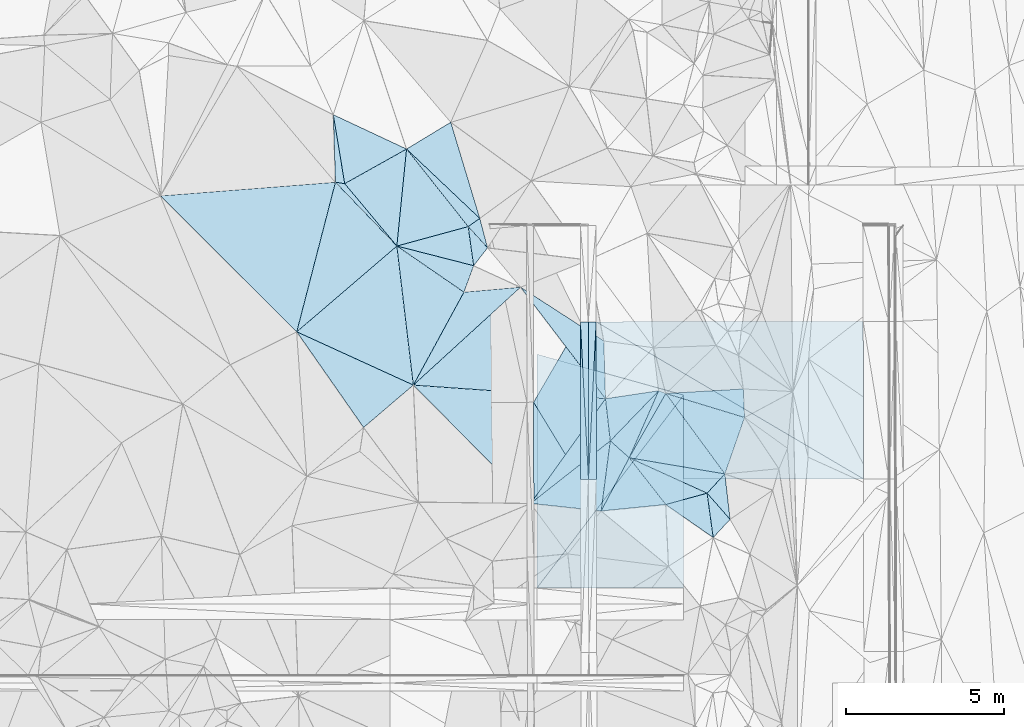
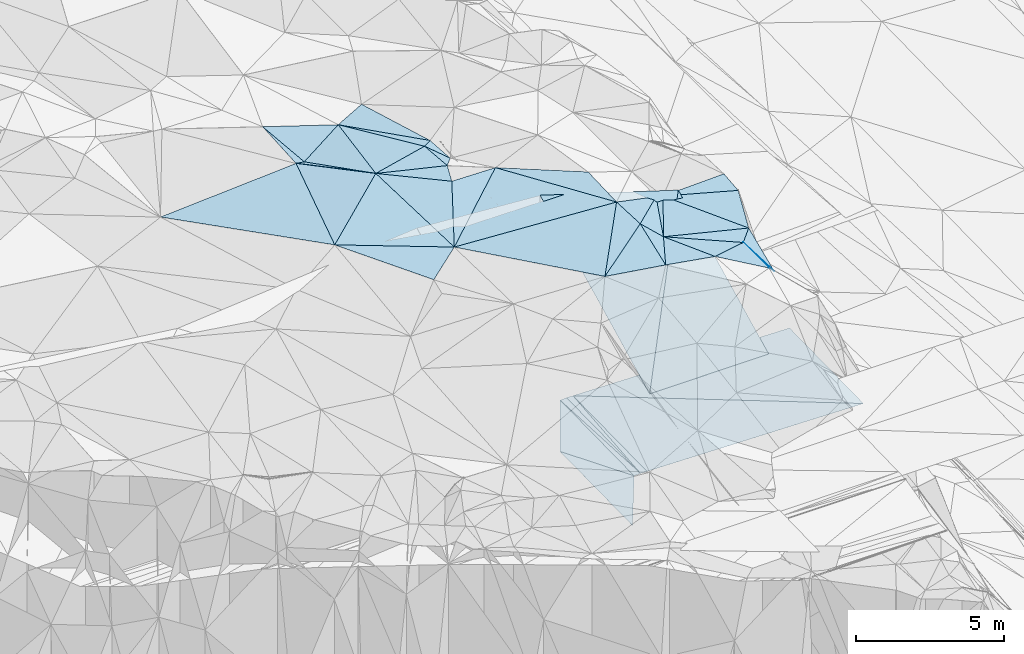
# One storey, part 79 of 275: 45 plates.
"""IFC2X3 building model written with IfcOpenShell, lengths in millimetres."""

from ifc_helpers import new_model, si_unit, frame, origin_with_axes, place, context, subcontext, project, spatial, polyline, outline, extrude, material, type_object, element, save


model = new_model("IFC2X3")

# Units and contexts
model_context = context("Model", 3, precision=1e-05, world=origin_with_axes())
body_context = subcontext(model_context, "Body", "Model", "MODEL_VIEW")
ifc_project = project(units=[si_unit("LENGTHUNIT", "METRE", prefix="MILLI"), si_unit("AREAUNIT", "SQUARE_METRE"), si_unit("VOLUMEUNIT", "CUBIC_METRE"), si_unit("MASSUNIT", "GRAM", prefix="KILO"), si_unit("TIMEUNIT", "SECOND"), si_unit("PLANEANGLEUNIT", "RADIAN"), si_unit("SOLIDANGLEUNIT", "STERADIAN"), si_unit("THERMODYNAMICTEMPERATUREUNIT", "DEGREE_CELSIUS"), si_unit("LUMINOUSINTENSITYUNIT", "LUMEN")], contexts=[model_context])

# Site, building, storey
site_placement = place(None, origin_with_axes())
site = spatial("IfcSite", under=ifc_project, at=site_placement, CompositionType="ELEMENT")
building_placement = place(site_placement, origin_with_axes())
building = spatial("IfcBuilding", under=site, at=building_placement, Name="Undefined", CompositionType="ELEMENT")
storey_placement = place(building_placement, origin_with_axes())
storey = spatial("IfcBuildingStorey", under=building, at=storey_placement, Name="Undefined", CompositionType="ELEMENT", Elevation=0.0)

# Plates
ifc_material = material()
plate_type_1 = type_object("IfcPlateType", PredefinedType="NOTDEFINED")
plate_1_placement = place(storey_placement, frame((-104094.644782462, 77711.1310853138, 42792.426719318), z_axis=(0.0499115279560036, 0.0195072604842656, -0.99856312077179), x_axis=(0.998751970162793, 0.000855051097686835, 0.0499376709865296)))
element("IfcPlate", 1, at=plate_1_placement, inside=storey, type_object=plate_type_1, material=ifc_material, Name="00_PR", context=body_context, shape_type="SweptSolid", body=[
    extrude(outline(polyline([(0.0, 0.0), (250.312026977539, 1.89174897968769e-10), (247.52180480957, 4982.27783203125), (0.0, 0.0)])), frame((-8.85201319254618e-08, 2.18876761149539e-07, -0.5000001331573), z_axis=(0.0, 0.0, 1.0), x_axis=(1.0, 0.0, 0.0)), (0.0, 0.0, 1.0), 1.0),
])
plate_2_placement = place(storey_placement, frame((-104094.644782462, 77711.1310853138, 42792.426719318), z_axis=(0.0498953511236693, 0.0195064415090151, -0.998563945211272), x_axis=(0.0513830470798486, -0.998535363603699, -0.0169384209895411)))
element("IfcPlate", 2, at=plate_2_placement, inside=storey, type_object=plate_type_1, material=ifc_material, Name="00_PR", context=body_context, shape_type="SweptSolid", body=[
    extrude(outline(polyline([(0.0, 0.0), (4988.42236328125, 3.48954927176237e-08), (4976.20849609375, 250.014541625977), (0.0, 0.0)])), frame((-8.85201319254618e-08, 2.18876761149539e-07, -0.5000001331573), z_axis=(0.0, 0.0, 1.0), x_axis=(1.0, 0.0, 0.0)), (0.0, 0.0, 1.0), 1.0),
])
plate_3_placement = place(storey_placement, frame((-103594.680469558, 77711.5591088604, 42799.9261959315), z_axis=(-0.0200088869669632, 0.0194389401804357, -0.999610810289187), x_axis=(-0.0488496159024904, -0.998635870197029, -0.0184421740041923)))
element("IfcPlate", 3, at=plate_3_placement, inside=storey, type_object=plate_type_1, material=ifc_material, Name="00_PR", context=body_context, shape_type="SweptSolid", body=[
    extrude(outline(polyline([(0.0, 0.0), (4988.34912109375, -2.07655830308795e-08), (12.333911895752, 249.745346069336), (0.0, 0.0)])), frame((-8.85201319254618e-08, 2.18876761149539e-07, -0.5000001331573), z_axis=(0.0, 0.0, 1.0), x_axis=(1.0, 0.0, 0.0)), (0.0, 0.0, 1.0), 1.0),
])
plate_4_placement = place(storey_placement, frame((-103838.359411258, 72730.0148818088, 42707.9301957771), z_axis=(-0.0200249727975942, 0.0194397208131985, -0.999610472993936), x_axis=(0.0488496158985749, 0.998635870197188, 0.0184421740059628)))
element("IfcPlate", 4, at=plate_4_placement, inside=storey, type_object=plate_type_1, material=ifc_material, Name="00_PR", context=body_context, shape_type="SweptSolid", body=[
    extrude(outline(polyline([(0.0, 0.0), (4988.34912109375, -2.07655830308795e-08), (12.5400276184082, 249.734832763672), (0.0, 0.0)])), frame((-8.85201319254618e-08, 2.18876761149539e-07, -0.5000001331573), z_axis=(0.0, 0.0, 1.0), x_axis=(1.0, 0.0, 0.0)), (0.0, 0.0, 1.0), 1.0),
])
plate_type_2 = type_object("IfcPlateType", PredefinedType="NOTDEFINED")
plate_5_placement = place(storey_placement, frame((-101618.017587406, 75531.2384662934, 51629.5000677969), z_axis=(0.00624082271276018, 0.0161315410796943, -0.999850401567285), x_axis=(0.932639023347854, -0.360810825958369, 1.38790676176126e-10)))
element("IfcPlate", 5, at=plate_5_placement, inside=storey, type_object=plate_type_2, material=ifc_material, Name="00", context=body_context, shape_type="SweptSolid", body=[
    extrude(outline(polyline([(0.0, 0.0), (240.416305541992, 8.0763129517436e-10), (-106.066017150879, 2312.58520507813), (0.0, 0.0)])), frame((-8.85201319254618e-08, 2.18876761149539e-07, -0.5000001331573), z_axis=(0.0, 0.0, 1.0), x_axis=(1.0, 0.0, 0.0)), (0.0, 0.0, 1.0), 1.0),
])
plate_type_3 = type_object("IfcPlateType", PredefinedType="NOTDEFINED")
plate_6_placement = place(storey_placement, frame((-105563.740608204, 70283.051901466, 42647.6330961536), z_axis=(4.16340783486055e-05, 0.0195077275703737, -0.999809705309787), x_axis=(-0.00168204510044178, 0.999808293172789, 0.0195076299738202)))
element("IfcPlate", 6, at=plate_6_placement, inside=storey, type_object=plate_type_3, material=ifc_material, Name="00_PR", context=body_context, shape_type="SweptSolid", body=[
    extrude(outline(polyline([(0.0, 0.0), (4885.9345703125, 8.57107806950808e-09), (2444.52392578125, 1479.50512695313), (0.0, 0.0)])), frame((-8.85201319254618e-08, 2.18876761149539e-07, -0.5000001331573), z_axis=(0.0, 0.0, 1.0), x_axis=(1.0, 0.0, 0.0)), (0.0, 0.0, 1.0), 1.0),
])
plate_type_4 = type_object("IfcPlateType", PredefinedType="NOTDEFINED")
plate_7_placement = place(storey_placement, frame((-105571.959004431, 75168.0496738251, 42742.9460960159), z_axis=(-2.47095844767252e-05, 0.0194673778358508, -0.999810492338239), x_axis=(0.502232605744066, 0.864568933754898, 0.0168216679745114)))
element("IfcPlate", 7, at=plate_7_placement, inside=storey, type_object=plate_type_4, material=ifc_material, Name="00_PR", context=body_context, shape_type="SweptSolid", body=[
    extrude(outline(polyline([(0.0, 0.0), (2941.4443359375, -1.75496097654104e-08), (-1363.89514160156, 2507.82983398438), (0.0, 0.0)])), frame((-8.85201319254618e-08, 2.18876761149539e-07, -0.5000001331573), z_axis=(0.0, 0.0, 1.0), x_axis=(1.0, 0.0, 0.0)), (0.0, 0.0, 1.0), 1.0),
])
plate_type_5 = type_object("IfcPlateType", PredefinedType="NOTDEFINED")
plate_8_placement = place(storey_placement, frame((-103594.680469558, 77711.5591088604, 42799.9261959315), z_axis=(-0.0200101558426408, 0.0194676111996677, -0.999610226927142), x_axis=(0.999799658022717, 0.000876953113859866, -0.0199968690272809)))
element("IfcPlate", 8, at=plate_8_placement, inside=storey, type_object=plate_type_5, material=ifc_material, Name="00_PR", context=body_context, shape_type="SweptSolid", body=[
    extrude(outline(polyline([(0.0, 0.0), (8442.771484375, -2.21189111471176e-09), (8446.765625, 4975.095703125), (0.0, 0.0)])), frame((-8.85201319254618e-08, 2.18876761149539e-07, -0.5000001331573), z_axis=(0.0, 0.0, 1.0), x_axis=(1.0, 0.0, 0.0)), (0.0, 0.0, 1.0), 1.0),
])
plate_type_6 = type_object("IfcPlateType", PredefinedType="NOTDEFINED")
plate_9_placement = place(storey_placement, frame((-95147.1826396286, 72744.8154070704, 42534.0961952218), z_axis=(-0.020026562689852, 0.0194397178099337, -0.999610441201121), x_axis=(-0.99979858505382, -0.00170321912043205, 0.0199972090304668)))
element("IfcPlate", 9, at=plate_9_placement, inside=storey, type_object=plate_type_6, material=ifc_material, Name="00_PR", context=body_context, shape_type="SweptSolid", body=[
    extrude(outline(polyline([(0.0, 0.0), (8442.8779296875, 9.31322574615479e-10), (8442.65234375, 4982.072265625), (0.0, 0.0)])), frame((-8.85201319254618e-08, 2.18876761149539e-07, -0.5000001331573), z_axis=(0.0, 0.0, 1.0), x_axis=(1.0, 0.0, 0.0)), (0.0, 0.0, 1.0), 1.0),
])
plate_type_7 = type_object("IfcPlateType", PredefinedType="NOTDEFINED")
plate_10_placement = place(storey_placement, frame((-109372.918102047, 75711.0015704377, 52159.503996703), z_axis=(-0.0424843865869005, 0.119112827589882, -0.991971376199877), x_axis=(-0.906017638237855, 0.413883575863438, 0.088500987748122)))
element("IfcPlate", 10, at=plate_10_placement, inside=storey, type_object=plate_type_7, material=ifc_material, Name="00", context=body_context, shape_type="SweptSolid", body=[
    extrude(outline(polyline([(0.0, 0.0), (4067.75122070313, 2.28319549933076e-08), (2339.84326171875, 3796.12084960938), (0.0, 0.0)])), frame((-8.85201319254618e-08, 2.18876761149539e-07, -0.5000001331573), z_axis=(0.0, 0.0, 1.0), x_axis=(1.0, 0.0, 0.0)), (0.0, 0.0, 1.0), 1.0),
])
plate_type_8 = type_object("IfcPlateType", PredefinedType="NOTDEFINED")
plate_11_placement = place(storey_placement, frame((-109894.236215448, 80105.3789736677, 52709.502000343), z_axis=(0.08945127564701, 0.00405021772779605, -0.995982964222521), x_axis=(-0.640329731326981, 0.766171760121747, -0.0543936500950232)))
element("IfcPlate", 11, at=plate_11_placement, inside=storey, type_object=plate_type_8, material=ifc_material, Name="00", context=body_context, shape_type="SweptSolid", body=[
    extrude(outline(polyline([(0.0, 0.0), (2573.82983398438, -3.59432306140661e-09), (2150.4140625, 2206.83471679688), (0.0, 0.0)])), frame((-8.85201319254618e-08, 2.18876761149539e-07, -0.5000001331573), z_axis=(0.0, 0.0, 1.0), x_axis=(1.0, 0.0, 0.0)), (0.0, 0.0, 1.0), 1.0),
])
plate_type_9 = type_object("IfcPlateType", PredefinedType="NOTDEFINED")
plate_12_placement = place(storey_placement, frame((-100829.739268023, 75394.5654516798, 51708.8947862122), z_axis=(0.00401439643131906, 0.447209958192911, -0.894420000846575), x_axis=(-5.11789581372139e-05, -0.894427148801689, -0.447213676967951)))
element("IfcPlate", 12, at=plate_12_placement, inside=storey, type_object=plate_type_9, material=ifc_material, Name="00_PR", context=body_context, shape_type="SweptSolid", body=[
    extrude(outline(polyline([(0.0, 0.0), (6821.87890625, -4.57512214779854e-08), (6831.1298828125, 4638.80615234375), (0.0, 0.0)])), frame((-8.85201319254618e-08, 2.18876761149539e-07, -0.5000001331573), z_axis=(0.0, 0.0, 1.0), x_axis=(1.0, 0.0, 0.0)), (0.0, 0.0, 1.0), 1.0),
])
plate_type_10 = type_object("IfcPlateType", PredefinedType="NOTDEFINED")
plate_13_placement = place(storey_placement, frame((-105468.85778225, 69293.1580861564, 48637.3697850271), z_axis=(0.00401439643131906, 0.447209958192911, -0.894420000846575), x_axis=(5.12609174268665e-05, 0.894427213806252, 0.447213546949446)))
element("IfcPlate", 13, at=plate_13_placement, inside=storey, type_object=plate_type_10, material=ifc_material, Name="00_PR", context=body_context, shape_type="SweptSolid", body=[
    extrude(outline(polyline([(0.0, 0.0), (8266.154296875, 5.1964889280498e-08), (6831.13037109375, 4638.8056640625), (0.0, 0.0)])), frame((-8.85201319254618e-08, 2.18876761149539e-07, -0.5000001331573), z_axis=(0.0, 0.0, 1.0), x_axis=(1.0, 0.0, 0.0)), (0.0, 0.0, 1.0), 1.0),
])
plate_type_11 = type_object("IfcPlateType", PredefinedType="NOTDEFINED")
plate_14_placement = place(storey_placement, frame((-107640.148772457, 80719.3908715709, 52669.5263252078), z_axis=(-0.261202900071324, 0.185393050024925, -0.947313286086913), x_axis=(0.810020855690639, 0.575867445029905, -0.11064763486372)))
element("IfcPlate", 14, at=plate_14_placement, inside=storey, type_object=plate_type_11, material=ifc_material, Name="00", context=body_context, shape_type="SweptSolid", body=[
    extrude(outline(polyline([(0.0, 0.0), (451.884948730469, 6.69388100504875e-10), (144.284515380859, 944.92431640625), (0.0, 0.0)])), frame((-8.85201319254618e-08, 2.18876761149539e-07, -0.5000001331573), z_axis=(0.0, 0.0, 1.0), x_axis=(1.0, 0.0, 0.0)), (0.0, 0.0, 1.0), 1.0),
])
plate_type_12 = type_object("IfcPlateType", PredefinedType="NOTDEFINED")
plate_15_placement = place(storey_placement, frame((-109894.249426074, 80105.375151897, 52709.5009800692), z_axis=(0.0630464638512558, -0.00363821455273105, -0.998003961310135), x_axis=(-0.758610626117883, -0.649949807377444, -0.0455539880916829)))
element("IfcPlate", 15, at=plate_15_placement, inside=storey, type_object=plate_type_12, material=ifc_material, Name="00", context=body_context, shape_type="SweptSolid", body=[
    extrude(outline(polyline([(0.0, 0.0), (4170.875, 3.28291207551956e-08), (167.614700317383, 2797.73217773438), (0.0, 0.0)])), frame((-8.85201319254618e-08, 2.18876761149539e-07, -0.5000001331573), z_axis=(0.0, 0.0, 1.0), x_axis=(1.0, 0.0, 0.0)), (0.0, 0.0, 1.0), 1.0),
])
plate_type_13 = type_object("IfcPlateType", PredefinedType="NOTDEFINED")
plate_16_placement = place(storey_placement, frame((-107465.796251951, 79484.3194922299, 52559.5012725631), z_axis=(-0.0479332469146287, 0.0534653455888724, -0.997418598513826), x_axis=(-0.345767543557187, -0.937716688509573, -0.0336484459235405)))
element("IfcPlate", 16, at=plate_16_placement, inside=storey, type_object=plate_type_13, material=ifc_material, Name="00", context=body_context, shape_type="SweptSolid", body=[
    extrude(outline(polyline([(0.0, 0.0), (891.571655273438, 4.30736690759659e-09), (252.251174926758, 2498.45336914063), (0.0, 0.0)])), frame((-8.85201319254618e-08, 2.18876761149539e-07, -0.5000001331573), z_axis=(0.0, 0.0, 1.0), x_axis=(1.0, 0.0, 0.0)), (0.0, 0.0, 1.0), 1.0),
])
plate_type_14 = type_object("IfcPlateType", PredefinedType="NOTDEFINED")
plate_17_placement = place(storey_placement, frame((-102551.274391549, 73413.0873306711, 51589.507800875), z_axis=(-0.102743226010443, 0.143219198698545, -0.984343482039229), x_axis=(0.978177130287567, -0.16511346138306, -0.12612314082866)))
element("IfcPlate", 17, at=plate_17_placement, inside=storey, type_object=plate_type_14, material=ifc_material, Name="00", context=body_context, shape_type="SweptSolid", body=[
    extrude(outline(polyline([(0.0, 0.0), (3092.21606445313, -1.52213033288717e-08), (2647.1630859375, 699.519714355469), (0.0, 0.0)])), frame((-8.85201319254618e-08, 2.18876761149539e-07, -0.5000001331573), z_axis=(0.0, 0.0, 1.0), x_axis=(1.0, 0.0, 0.0)), (0.0, 0.0, 1.0), 1.0),
])
plate_type_15 = type_object("IfcPlateType", PredefinedType="NOTDEFINED")
plate_18_placement = place(storey_placement, frame((-103436.891331539, 71731.3669856792, 51759.5044286829), z_axis=(-0.0583370506278532, 0.119417171706982, -0.99112881484979), x_axis=(-0.991720817456399, 0.106836700823929, 0.0712442248934615)))
element("IfcPlate", 18, at=plate_18_placement, inside=storey, type_object=plate_type_15, material=ifc_material, Name="00", context=body_context, shape_type="SweptSolid", body=[
    extrude(outline(polyline([(0.0, 0.0), (2245.79614257813, 1.48429535329342e-09), (-31.7036800384521, 2248.3759765625), (0.0, 0.0)])), frame((-8.85201319254618e-08, 2.18876761149539e-07, -0.5000001331573), z_axis=(0.0, 0.0, 1.0), x_axis=(1.0, 0.0, 0.0)), (0.0, 0.0, 1.0), 1.0),
])
plate_type_16 = type_object("IfcPlateType", PredefinedType="NOTDEFINED")
plate_19_placement = place(storey_placement, frame((-109894.280336887, 80105.4391137231, 52709.5038719452), z_axis=(0.00120830272819888, 0.124330446541354, -0.992240132260001), x_axis=(0.822128946847772, -0.565006678668483, -0.0697957578580838)))
element("IfcPlate", 19, at=plate_19_placement, inside=storey, type_object=plate_type_16, material=ifc_material, Name="00", context=body_context, shape_type="SweptSolid", body=[
    extrude(outline(polyline([(0.0, 0.0), (2578.95336914063, -7.80710252001882e-09), (2949.91772460938, 3344.15698242188), (0.0, 0.0)])), frame((-8.85201319254618e-08, 2.18876761149539e-07, -0.5000001331573), z_axis=(0.0, 0.0, 1.0), x_axis=(1.0, 0.0, 0.0)), (0.0, 0.0, 1.0), 1.0),
])
plate_type_17 = type_object("IfcPlateType", PredefinedType="NOTDEFINED")
plate_20_placement = place(storey_placement, frame((-103352.179348122, 77104.404641422, 52299.5018860323), z_axis=(0.0269184658026584, 0.0826657823630834, -0.996213714332989), x_axis=(0.0285336282030727, -0.996232314273623, -0.0818963250615655)))
element("IfcPlate", 20, at=plate_20_placement, inside=storey, type_object=plate_type_17, material=ifc_material, Name="00", context=body_context, shape_type="SweptSolid", body=[
    extrude(outline(polyline([(0.0, 0.0), (1831.583984375, 2.18278728425503e-10), (-1775.23937988281, 2583.83935546875), (0.0, 0.0)])), frame((-8.85201319254618e-08, 2.18876761149539e-07, -0.5000001331573), z_axis=(0.0, 0.0, 1.0), x_axis=(1.0, 0.0, 0.0)), (0.0, 0.0, 1.0), 1.0),
])
plate_type_18 = type_object("IfcPlateType", PredefinedType="NOTDEFINED")
plate_21_placement = place(storey_placement, frame((-109372.948451286, 75711.0317195909, 52159.510811722), z_axis=(-0.103215070282376, 0.179420044480136, -0.978343036416854), x_axis=(0.475187264867613, 0.87298596323488, 0.109966228008901)))
element("IfcPlate", 21, at=plate_21_placement, inside=storey, type_object=plate_type_18, material=ifc_material, Name="00", context=body_context, shape_type="SweptSolid", body=[
    extrude(outline(polyline([(0.0, 0.0), (3364.66943359375, 5.99538907408714e-09), (4334.333984375, 1520.4443359375), (0.0, 0.0)])), frame((-8.85201319254618e-08, 2.18876761149539e-07, -0.5000001331573), z_axis=(0.0, 0.0, 1.0), x_axis=(1.0, 0.0, 0.0)), (0.0, 0.0, 1.0), 1.0),
])
plate_type_19 = type_object("IfcPlateType", PredefinedType="NOTDEFINED")
plate_22_placement = place(storey_placement, frame((-117363.11470885, 81690.7903295136, 52569.5000288199), z_axis=(0.000834528412102019, 0.0124732808125638, -0.999921857360914), x_axis=(0.996960342197155, 0.0778898122067393, 0.0018036741752551)))
element("IfcPlate", 22, at=plate_22_placement, inside=storey, type_object=plate_type_19, material=ifc_material, Name="00", context=body_context, shape_type="SweptSolid", body=[
    extrude(outline(polyline([(0.0, 0.0), (5544.240234375, -6.53380993753672e-09), (3956.95336914063, 4618.86572265625), (0.0, 0.0)])), frame((-8.85201319254618e-08, 2.18876761149539e-07, -0.5000001331573), z_axis=(0.0, 0.0, 1.0), x_axis=(1.0, 0.0, 0.0)), (0.0, 0.0, 1.0), 1.0),
])
plate_type_20 = type_object("IfcPlateType", PredefinedType="NOTDEFINED")
plate_23_placement = place(storey_placement, frame((-103299.952395257, 75279.7299230715, 52149.5029351971), z_axis=(-0.0426612703769056, 0.099594682755939, -0.994113129968905), x_axis=(0.112521919235564, -0.988209360144718, -0.103831971058594)))
element("IfcPlate", 23, at=plate_23_placement, inside=storey, type_object=plate_type_20, material=ifc_material, Name="00", context=body_context, shape_type="SweptSolid", body=[
    extrude(outline(polyline([(0.0, 0.0), (1348.33227539063, 1.71712599694729e-09), (3027.29516601563, 2724.5703125), (0.0, 0.0)])), frame((-8.85201319254618e-08, 2.18876761149539e-07, -0.5000001331573), z_axis=(0.0, 0.0, 1.0), x_axis=(1.0, 0.0, 0.0)), (0.0, 0.0, 1.0), 1.0),
])
plate_type_21 = type_object("IfcPlateType", PredefinedType="NOTDEFINED")
plate_24_placement = place(storey_placement, frame((-105664.063318216, 71971.2742854486, 51919.5011216795), z_axis=(0.0031241781235292, 0.0671295595838872, -0.997739375659358), x_axis=(-0.703440316903041, 0.709295184604608, 0.0455199039109672)))
element("IfcPlate", 24, at=plate_24_placement, inside=storey, type_object=plate_type_21, material=ifc_material, Name="00", context=body_context, shape_type="SweptSolid", body=[
    extrude(outline(polyline([(0.0, 0.0), (5272.4189453125, 1.16779119707644e-09), (694.102661132813, 4013.23071289063), (0.0, 0.0)])), frame((-8.85201319254618e-08, 2.18876761149539e-07, -0.5000001331573), z_axis=(0.0, 0.0, 1.0), x_axis=(1.0, 0.0, 0.0)), (0.0, 0.0, 1.0), 1.0),
])
plate_type_22 = type_object("IfcPlateType", PredefinedType="NOTDEFINED")
plate_25_placement = place(storey_placement, frame((-100088.547425498, 72293.3336495574, 51169.6889610928), z_axis=(-0.78287703997348, 0.0119130016132518, -0.622062392911615), x_axis=(0.504103260418382, -0.573865491089101, -0.645413279203815)))
element("IfcPlate", 25, at=plate_25_placement, inside=storey, type_object=plate_type_22, material=ifc_material, Name="00", context=body_context, shape_type="SweptSolid", body=[
    extrude(outline(polyline([(0.0, 0.0), (1440.93725585938, -8.9130480773747e-10), (1075.96643066406, 957.547058105469), (0.0, 0.0)])), frame((-8.85201319254618e-08, 2.18876761149539e-07, -0.5000001331573), z_axis=(0.0, 0.0, 1.0), x_axis=(1.0, 0.0, 0.0)), (0.0, 0.0, 1.0), 1.0),
])
plate_type_23 = type_object("IfcPlateType", PredefinedType="NOTDEFINED")
plate_26_placement = place(storey_placement, frame((-99526.7158601399, 72902.6781538372, 51199.6183855585), z_axis=(-0.455854762584172, 0.457930781985056, -0.76321414710413), x_axis=(0.0949248522882564, -0.827587694194315, -0.553252095193674)))
element("IfcPlate", 26, at=plate_26_placement, inside=storey, type_object=plate_type_23, material=ifc_material, Name="00", context=body_context, shape_type="SweptSolid", body=[
    extrude(outline(polyline([(0.0, 0.0), (1735.19445800781, -1.16997398436069e-08), (467.382751464844, 684.801696777344), (0.0, 0.0)])), frame((-8.85201319254618e-08, 2.18876761149539e-07, -0.5000001331573), z_axis=(0.0, 0.0, 1.0), x_axis=(1.0, 0.0, 0.0)), (0.0, 0.0, 1.0), 1.0),
])
plate_type_24 = type_object("IfcPlateType", PredefinedType="NOTDEFINED")
plate_27_placement = place(storey_placement, frame((-102551.279660649, 73413.0577472824, 51589.5050038124), z_axis=(-0.113444058079821, 0.0841272177214205, -0.989976291092284), x_axis=(0.494964677961901, 0.868744704364515, 0.0171057361338932)))
element("IfcPlate", 27, at=plate_27_placement, inside=storey, type_object=plate_type_24, material=ifc_material, Name="00", context=body_context, shape_type="SweptSolid", body=[
    extrude(outline(polyline([(0.0, 0.0), (2338.39697265625, -6.66477717459202e-09), (1046.91381835938, 2909.59985351563), (0.0, 0.0)])), frame((-8.85201319254618e-08, 2.18876761149539e-07, -0.5000001331573), z_axis=(0.0, 0.0, 1.0), x_axis=(1.0, 0.0, 0.0)), (0.0, 0.0, 1.0), 1.0),
])
plate_type_25 = type_object("IfcPlateType", PredefinedType="NOTDEFINED")
plate_28_placement = place(storey_placement, frame((-103148.448561385, 73947.3250710095, 52009.5655816061), z_axis=(-0.468870579086385, 0.159094565412475, -0.868820637026661), x_axis=(0.659991257359202, -0.590606747976077, -0.464322312036092)))
element("IfcPlate", 28, at=plate_28_placement, inside=storey, type_object=plate_type_25, material=ifc_material, Name="00", context=body_context, shape_type="SweptSolid", body=[
    extrude(outline(polyline([(0.0, 0.0), (904.544067382813, 4.54019755125046e-09), (1234.32348632813, 1879.53332519531), (0.0, 0.0)])), frame((-8.85201319254618e-08, 2.18876761149539e-07, -0.5000001331573), z_axis=(0.0, 0.0, 1.0), x_axis=(1.0, 0.0, 0.0)), (0.0, 0.0, 1.0), 1.0),
])
plate_type_26 = type_object("IfcPlateType", PredefinedType="NOTDEFINED")
plate_29_placement = place(storey_placement, frame((-99895.0064686403, 70891.8537124908, 50899.5111910996), z_axis=(-0.121947828891443, 0.171517209932465, -0.97760450782801), x_axis=(-0.804708028521867, 0.559487818088166, 0.198540600994842)))
element("IfcPlate", 29, at=plate_29_placement, inside=storey, type_object=plate_type_26, material=ifc_material, Name="00", context=body_context, shape_type="SweptSolid", body=[
    extrude(outline(polyline([(0.0, 0.0), (1863.5986328125, -2.02635419555008e-09), (993.239624023438, 1043.1083984375), (0.0, 0.0)])), frame((-8.85201319254618e-08, 2.18876761149539e-07, -0.5000001331573), z_axis=(0.0, 0.0, 1.0), x_axis=(1.0, 0.0, 0.0)), (0.0, 0.0, 1.0), 1.0),
])
plate_type_27 = type_object("IfcPlateType", PredefinedType="NOTDEFINED")
plate_30_placement = place(storey_placement, frame((-113058.38506023, 77394.5497141232, 52519.5021873876), z_axis=(-0.0677365984436262, 0.0646119283224315, -0.99560888502953), x_axis=(0.906017638307265, -0.413883575893536, -0.0885009868967903)))
element("IfcPlate", 30, at=plate_30_placement, inside=storey, type_object=plate_type_27, material=ifc_material, Name="00", context=body_context, shape_type="SweptSolid", body=[
    extrude(outline(polyline([(0.0, 0.0), (4067.75122070313, 2.28319549933076e-08), (3196.09033203125, 1873.26110839844), (0.0, 0.0)])), frame((-8.85201319254618e-08, 2.18876761149539e-07, -0.5000001331573), z_axis=(0.0, 0.0, 1.0), x_axis=(1.0, 0.0, 0.0)), (0.0, 0.0, 1.0), 1.0),
])
plate_type_28 = type_object("IfcPlateType", PredefinedType="NOTDEFINED")
plate_31_placement = place(storey_placement, frame((-100088.211159355, 72293.3912042277, 51169.507121813), z_axis=(-0.110346449702483, 0.127018862347515, -0.985743308192351), x_axis=(-0.961659767781708, -0.264182132172222, 0.0736090488389199)))
element("IfcPlate", 31, at=plate_31_placement, inside=storey, type_object=plate_type_28, material=ifc_material, Name="00", context=body_context, shape_type="SweptSolid", body=[
    extrude(outline(polyline([(0.0, 0.0), (1358.52856445313, -3.40514816343784e-09), (2103.74658203125, 1752.44116210938), (0.0, 0.0)])), frame((-8.85201319254618e-08, 2.18876761149539e-07, -0.5000001331573), z_axis=(0.0, 0.0, 1.0), x_axis=(1.0, 0.0, 0.0)), (0.0, 0.0, 1.0), 1.0),
])
plate_type_29 = type_object("IfcPlateType", PredefinedType="NOTDEFINED")
plate_32_placement = place(storey_placement, frame((-101394.71613031, 71934.4416589704, 51269.5142491488), z_axis=(-0.235665467839818, 0.0259030979606526, -0.971488968946061), x_axis=(-0.967886695360361, -0.096264999264893, 0.232224879935225)))
element("IfcPlate", 32, at=plate_32_placement, inside=storey, type_object=plate_type_29, material=ifc_material, Name="00", context=body_context, shape_type="SweptSolid", body=[
    extrude(outline(polyline([(0.0, 0.0), (2110.02368164063, 6.11180439591408e-10), (1051.45739746094, 1587.71447753906), (0.0, 0.0)])), frame((-8.85201319254618e-08, 2.18876761149539e-07, -0.5000001331573), z_axis=(0.0, 0.0, 1.0), x_axis=(1.0, 0.0, 0.0)), (0.0, 0.0, 1.0), 1.0),
])
plate_type_30 = type_object("IfcPlateType", PredefinedType="NOTDEFINED")
plate_33_placement = place(storey_placement, frame((-109894.301098861, 80105.418477037, 52709.5021138553), z_axis=(-0.040274237277663, 0.0830062891092666, -0.99573487524542), x_axis=(0.964717748391179, 0.262729207345162, -0.0171181058192192)))
element("IfcPlate", 33, at=plate_33_placement, inside=storey, type_object=plate_type_30, material=ifc_material, Name="00", context=body_context, shape_type="SweptSolid", body=[
    extrude(outline(polyline([(0.0, 0.0), (2336.70703125, -1.65455276146531e-08), (2182.21606445313, 1242.51062011719), (0.0, 0.0)])), frame((-8.85201319254618e-08, 2.18876761149539e-07, -0.5000001331573), z_axis=(0.0, 0.0, 1.0), x_axis=(1.0, 0.0, 0.0)), (0.0, 0.0, 1.0), 1.0),
])
plate_type_31 = type_object("IfcPlateType", PredefinedType="NOTDEFINED")
plate_34_placement = place(storey_placement, frame((-111904.650456471, 84257.0766035268, 52819.5031510193), z_axis=(-0.0167210078373342, 0.111190975129169, -0.993658379397431), x_axis=(0.16291325724245, -0.98021386382853, -0.112427984830287)))
element("IfcPlate", 34, at=plate_34_placement, inside=storey, type_object=plate_type_31, material=ifc_material, Name="00", context=body_context, shape_type="SweptSolid", body=[
    extrude(outline(polyline([(0.0, 0.0), (2223.64575195313, -9.86619852483273e-09), (2130.37548828125, 281.958618164063), (0.0, 0.0)])), frame((-8.85201319254618e-08, 2.18876761149539e-07, -0.5000001331573), z_axis=(0.0, 0.0, 1.0), x_axis=(1.0, 0.0, 0.0)), (0.0, 0.0, 1.0), 1.0),
])
plate_type_32 = type_object("IfcPlateType", PredefinedType="NOTDEFINED")
plate_35_placement = place(storey_placement, frame((-103148.365965346, 73947.2781972912, 52009.5247124553), z_axis=(-0.303648165407862, 0.065299699330314, -0.950543918455013), x_axis=(-0.112521919238134, 0.988209360165637, 0.103831970856716)))
element("IfcPlate", 35, at=plate_35_placement, inside=storey, type_object=plate_type_32, material=ifc_material, Name="00", context=body_context, shape_type="SweptSolid", body=[
    extrude(outline(polyline([(0.0, 0.0), (1348.33227539063, 1.71712599694729e-09), (1353.67224121094, 1778.33386230469), (0.0, 0.0)])), frame((-8.85201319254618e-08, 2.18876761149539e-07, -0.5000001331573), z_axis=(0.0, 0.0, 1.0), x_axis=(1.0, 0.0, 0.0)), (0.0, 0.0, 1.0), 1.0),
])
plate_type_33 = type_object("IfcPlateType", PredefinedType="NOTDEFINED")
plate_36_placement = place(storey_placement, frame((-107027.256899072, 80050.0063951187, 52369.546451275), z_axis=(-0.420489635115099, 0.0214624107476468, -0.907043456338047), x_axis=(-0.592331954324774, -0.763766320090106, 0.256522638731576)))
element("IfcPlate", 36, at=plate_36_placement, inside=storey, type_object=plate_type_33, material=ifc_material, Name="00", context=body_context, shape_type="SweptSolid", body=[
    extrude(outline(polyline([(0.0, 0.0), (740.675354003906, -1.16415321826935e-10), (-71.1512756347656, 953.224792480469), (0.0, 0.0)])), frame((-8.85201319254618e-08, 2.18876761149539e-07, -0.5000001331573), z_axis=(0.0, 0.0, 1.0), x_axis=(1.0, 0.0, 0.0)), (0.0, 0.0, 1.0), 1.0),
])
plate_type_34 = type_object("IfcPlateType", PredefinedType="NOTDEFINED")
plate_37_placement = place(storey_placement, frame((-101393.809900769, 75444.5672069093, 51629.5068045565), z_axis=(-0.0216187801446093, 0.163175847160292, -0.986360112356831), x_axis=(0.998218160190554, 0.0584060212093076, -0.0122164377902845)))
element("IfcPlate", 37, at=plate_37_placement, inside=storey, type_object=plate_type_34, material=ifc_material, Name="00", context=body_context, shape_type="SweptSolid", body=[
    extrude(outline(polyline([(0.0, 0.0), (2455.70751953125, -8.97853169590235e-09), (2442.63598632813, 914.783630371094), (0.0, 0.0)])), frame((-8.85201319254618e-08, 2.18876761149539e-07, -0.5000001331573), z_axis=(0.0, 0.0, 1.0), x_axis=(1.0, 0.0, 0.0)), (0.0, 0.0, 1.0), 1.0),
])
plate_type_35 = type_object("IfcPlateType", PredefinedType="NOTDEFINED")
plate_38_placement = place(storey_placement, frame((-109372.895372613, 75710.9742615894, 52159.5010265623), z_axis=(0.00293785577660439, 0.0645098163817212, -0.997912747986432), x_axis=(0.737643076960998, 0.67364119924654, 0.0457189860910557)))
element("IfcPlate", 38, at=plate_38_placement, inside=storey, type_object=plate_type_35, material=ifc_material, Name="00", context=body_context, shape_type="SweptSolid", body=[
    extrude(outline(polyline([(0.0, 0.0), (4593.27783203125, -4.56930138170719e-09), (4188.7080078125, 4418.33935546875), (0.0, 0.0)])), frame((-8.85201319254618e-08, 2.18876761149539e-07, -0.5000001331573), z_axis=(0.0, 0.0, 1.0), x_axis=(1.0, 0.0, 0.0)), (0.0, 0.0, 1.0), 1.0),
])
plate_type_36 = type_object("IfcPlateType", PredefinedType="NOTDEFINED")
plate_39_placement = place(storey_placement, frame((-101393.812322064, 75444.5595130948, 51629.5056530175), z_axis=(-0.0264714964106878, 0.147792926775912, -0.988664002921513), x_axis=(0.954317834747218, -0.290714766723655, -0.0690101057251178)))
element("IfcPlate", 39, at=plate_39_placement, inside=storey, type_object=plate_type_36, material=ifc_material, Name="00", context=body_context, shape_type="SweptSolid", body=[
    extrude(outline(polyline([(0.0, 0.0), (2608.31372070313, -5.11499820277095e-09), (2550.69018554688, 1904.64685058594), (0.0, 0.0)])), frame((-8.85201319254618e-08, 2.18876761149539e-07, -0.5000001331573), z_axis=(0.0, 0.0, 1.0), x_axis=(1.0, 0.0, 0.0)), (0.0, 0.0, 1.0), 1.0),
])
plate_type_37 = type_object("IfcPlateType", PredefinedType="NOTDEFINED")
plate_40_placement = place(storey_placement, frame((-102551.439073101, 73413.1192091393, 51589.5611440398), z_axis=(-0.43223510229002, 0.206999790611424, -0.877680980217278), x_axis=(-0.659991257385586, 0.590606748067022, 0.46432231188291)))
element("IfcPlate", 40, at=plate_40_placement, inside=storey, type_object=plate_type_37, material=ifc_material, Name="00", context=body_context, shape_type="SweptSolid", body=[
    extrude(outline(polyline([(0.0, 0.0), (904.544067382813, 4.54019755125046e-09), (653.699462890625, 2220.80541992188), (0.0, 0.0)])), frame((-8.85201319254618e-08, 2.18876761149539e-07, -0.5000001331573), z_axis=(0.0, 0.0, 1.0), x_axis=(1.0, 0.0, 0.0)), (0.0, 0.0, 1.0), 1.0),
])
plate_type_38 = type_object("IfcPlateType", PredefinedType="NOTDEFINED")
plate_41_placement = place(storey_placement, frame((-109587.729859257, 83171.1340434334, 52749.5001587177), z_axis=(-0.0218858948233021, 0.0152312386891318, -0.999644445278309), x_axis=(0.621808624096709, -0.782752663734163, -0.0255402117459708)))
element("IfcPlate", 41, at=plate_41_placement, inside=storey, type_object=plate_type_38, material=ifc_material, Name="00", context=body_context, shape_type="SweptSolid", body=[
    extrude(outline(polyline([(0.0, 0.0), (3132.3154296875, -2.04381649382412e-08), (2210.12231445313, 2147.03515625), (0.0, 0.0)])), frame((-8.85201319254618e-08, 2.18876761149539e-07, -0.5000001331573), z_axis=(0.0, 0.0, 1.0), x_axis=(1.0, 0.0, 0.0)), (0.0, 0.0, 1.0), 1.0),
])
plate_type_39 = type_object("IfcPlateType", PredefinedType="NOTDEFINED")
plate_42_placement = place(storey_placement, frame((-111542.368067848, 82077.4317414361, 52569.5036399061), z_axis=(0.0253458737353046, 0.11807054041638, -0.992681688241693), x_axis=(-0.162913257230826, 0.980213863831423, 0.112427984821909)))
element("IfcPlate", 42, at=plate_42_placement, inside=storey, type_object=plate_type_39, material=ifc_material, Name="00", context=body_context, shape_type="SweptSolid", body=[
    extrude(outline(polyline([(0.0, 0.0), (2223.64575195313, -9.86619852483273e-09), (773.909301757813, 2109.6123046875), (0.0, 0.0)])), frame((-8.85201319254618e-08, 2.18876761149539e-07, -0.5000001331573), z_axis=(0.0, 0.0, 1.0), x_axis=(1.0, 0.0, 0.0)), (0.0, 0.0, 1.0), 1.0),
])
plate_type_40 = type_object("IfcPlateType", PredefinedType="NOTDEFINED")
plate_43_placement = place(storey_placement, frame((-108191.013150551, 84018.2118659517, 52589.5024213187), z_axis=(-0.0913208547443096, -0.03738218582759, -0.99511962781945), x_axis=(0.288887786279342, -0.957316312060855, 0.009451222186854)))
element("IfcPlate", 43, at=plate_43_placement, inside=storey, type_object=plate_type_40, material=ifc_material, Name="00", context=body_context, shape_type="SweptSolid", body=[
    extrude(outline(polyline([(0.0, 0.0), (3174.19287109375, -3.31783667206764e-09), (408.954376220703, 1589.60888671875), (0.0, 0.0)])), frame((-8.85201319254618e-08, 2.18876761149539e-07, -0.5000001331573), z_axis=(0.0, 0.0, 1.0), x_axis=(1.0, 0.0, 0.0)), (0.0, 0.0, 1.0), 1.0),
])
plate_type_41 = type_object("IfcPlateType", PredefinedType="NOTDEFINED")
plate_44_placement = place(storey_placement, frame((-109587.769667928, 83171.1023366598, 52749.5031455697), z_axis=(-0.101475281701624, -0.0481884726934071, -0.993670286515126), x_axis=(0.725405638858281, -0.687113865538417, -0.0407577587394376)))
element("IfcPlate", 44, at=plate_44_placement, inside=storey, type_object=plate_type_41, material=ifc_material, Name="00", context=body_context, shape_type="SweptSolid", body=[
    extrude(outline(polyline([(0.0, 0.0), (3189.57666015625, -7.9016899690032e-09), (3100.81884765625, 443.082427978516), (0.0, 0.0)])), frame((-8.85201319254618e-08, 2.18876761149539e-07, -0.5000001331573), z_axis=(0.0, 0.0, 1.0), x_axis=(1.0, 0.0, 0.0)), (0.0, 0.0, 1.0), 1.0),
])
plate_type_42 = type_object("IfcPlateType", PredefinedType="NOTDEFINED")
plate_45_placement = place(storey_placement, frame((-111835.75324134, 82122.5672995489, 52579.5038627835), z_axis=(-0.0513053341291414, -0.113321194692292, -0.992232870612241), x_axis=(0.987749937946866, -0.152368872427044, -0.0336717507901521)))
element("IfcPlate", 45, at=plate_45_placement, inside=storey, type_object=plate_type_42, material=ifc_material, Name="00", context=body_context, shape_type="SweptSolid", body=[
    extrude(outline(polyline([(0.0, 0.0), (296.98486328125, 4.07453626394272e-10), (2220.65209960938, 1710.00134277344), (0.0, 0.0)])), frame((-8.85201319254618e-08, 2.18876761149539e-07, -0.5000001331573), z_axis=(0.0, 0.0, 1.0), x_axis=(1.0, 0.0, 0.0)), (0.0, 0.0, 1.0), 1.0),
])

save(model, "model.ifc")
